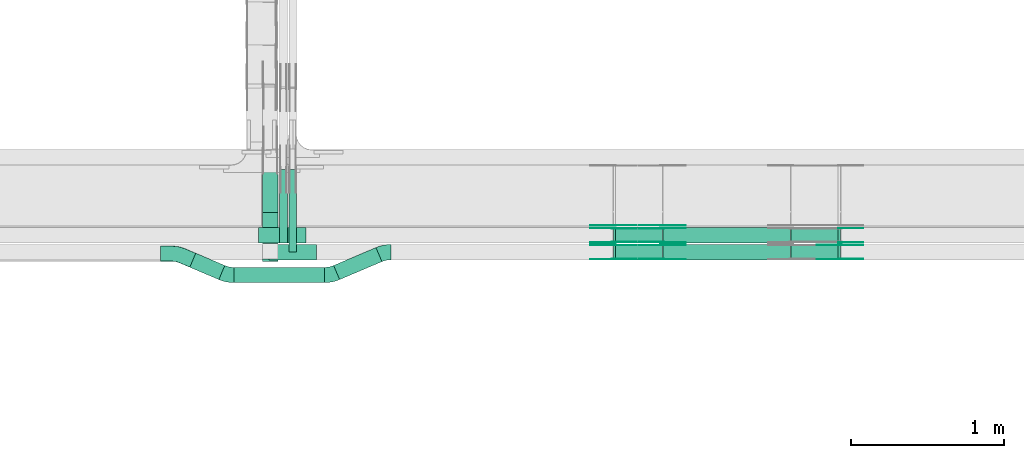
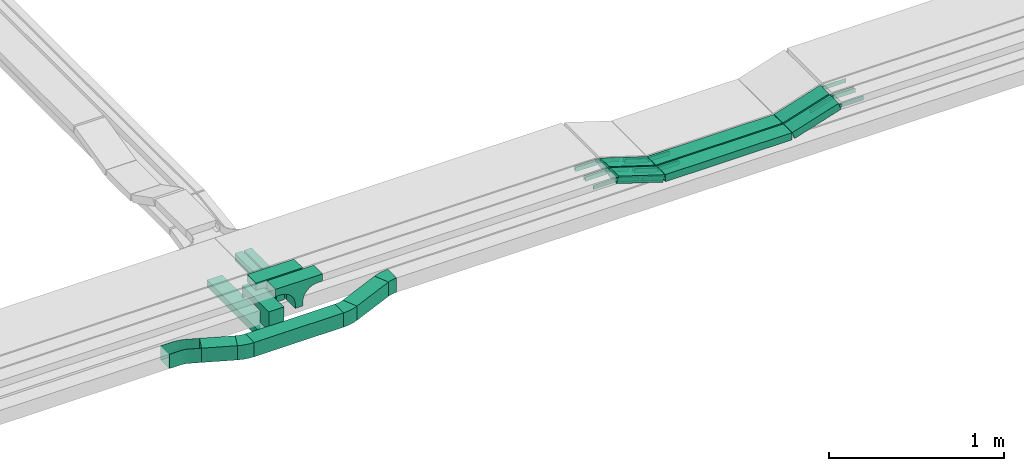
# One storey, part 15 of 27: 33 flow fittings, 12 flow segments.
"""IFC2X3 building model written with IfcOpenShell, lengths in millimetres."""

from ifc_helpers import new_model, entity, si_unit, converted_unit, derived_unit, direction, frame, frame_2d, origin, origin_2d_with_axis, place, context, subcontext, project, spatial, polyline, circle_curve, parameter, trimmed, segment, composite_curve, rectangle, outline, extrude, faceted_brep, source, transform, mapped, material, material_list, type_object, type_shapes, element, save


model = new_model("IFC2X3")

# Units and contexts
model_context = context("Model", 3, precision=0.01, world=origin(), true_north=direction((6.12303176911189e-17, 1.0)))
body_context = subcontext(model_context, "Body", "Model", "MODEL_VIEW")
ifc_project = project(units=[si_unit("LENGTHUNIT", "METRE", prefix="MILLI"), si_unit("AREAUNIT", "SQUARE_METRE"), si_unit("VOLUMEUNIT", "CUBIC_METRE"), converted_unit("PLANEANGLEUNIT", "DEGREE", entity("IfcRatioMeasure", 0.0174532925199433), si_unit("PLANEANGLEUNIT", "RADIAN"), dimensions=[0, 0, 0, 0, 0, 0, 0]), si_unit("MASSUNIT", "GRAM", prefix="KILO"), derived_unit("MASSDENSITYUNIT", [(si_unit("MASSUNIT", "GRAM", prefix="KILO"), 1), (si_unit("LENGTHUNIT", "METRE"), -3)]), derived_unit("MOMENTOFINERTIAUNIT", [(si_unit("LENGTHUNIT", "METRE"), 4)]), si_unit("TIMEUNIT", "SECOND"), si_unit("FREQUENCYUNIT", "HERTZ"), si_unit("THERMODYNAMICTEMPERATUREUNIT", "DEGREE_CELSIUS"), derived_unit("THERMALTRANSMITTANCEUNIT", [(si_unit("MASSUNIT", "GRAM", prefix="KILO"), 1), (si_unit("THERMODYNAMICTEMPERATUREUNIT", "KELVIN"), -1), (si_unit("TIMEUNIT", "SECOND"), -3)]), derived_unit("VOLUMETRICFLOWRATEUNIT", [(si_unit("LENGTHUNIT", "METRE"), 3), (si_unit("TIMEUNIT", "SECOND"), -1)]), derived_unit("MASSFLOWRATEUNIT", [(si_unit("MASSUNIT", "GRAM", prefix="KILO"), 1), (si_unit("TIMEUNIT", "SECOND"), -1)]), derived_unit("ROTATIONALFREQUENCYUNIT", [(si_unit("TIMEUNIT", "SECOND"), -1)]), si_unit("ELECTRICCURRENTUNIT", "AMPERE"), si_unit("ELECTRICVOLTAGEUNIT", "VOLT"), si_unit("POWERUNIT", "WATT"), si_unit("FORCEUNIT", "NEWTON", prefix="KILO"), si_unit("ILLUMINANCEUNIT", "LUX"), si_unit("LUMINOUSFLUXUNIT", "LUMEN"), si_unit("LUMINOUSINTENSITYUNIT", "CANDELA"), derived_unit("USERDEFINED", [(si_unit("MASSUNIT", "GRAM", prefix="KILO"), -1), (si_unit("LENGTHUNIT", "METRE"), -2), (si_unit("TIMEUNIT", "SECOND"), 3), (si_unit("LUMINOUSFLUXUNIT", "LUMEN"), 1)]), derived_unit("LINEARVELOCITYUNIT", [(si_unit("LENGTHUNIT", "METRE"), 1), (si_unit("TIMEUNIT", "SECOND"), -1)]), si_unit("PRESSUREUNIT", "PASCAL"), derived_unit("USERDEFINED", [(si_unit("LENGTHUNIT", "METRE"), -2), (si_unit("MASSUNIT", "GRAM", prefix="KILO"), 1), (si_unit("TIMEUNIT", "SECOND"), -2)]), derived_unit("LINEARFORCEUNIT", [(si_unit("MASSUNIT", "GRAM", prefix="KILO"), 1), (si_unit("LENGTHUNIT", "METRE"), 1), (si_unit("TIMEUNIT", "SECOND"), -2), (si_unit("LENGTHUNIT", "METRE"), -1)]), derived_unit("PLANARFORCEUNIT", [(si_unit("MASSUNIT", "GRAM", prefix="KILO"), 1), (si_unit("LENGTHUNIT", "METRE"), 1), (si_unit("TIMEUNIT", "SECOND"), -2), (si_unit("LENGTHUNIT", "METRE"), -2)])], contexts=[model_context])

# Site, building, storey
site_placement = place(None, origin())
site = spatial("IfcSite", under=ifc_project, at=site_placement, CompositionType="ELEMENT")
building_placement = place(site_placement, origin())
building = spatial("IfcBuilding", under=site, at=building_placement, CompositionType="ELEMENT")
storey_placement = place(building_placement, origin())
storey = spatial("IfcBuildingStorey", under=building, at=storey_placement, CompositionType="ELEMENT", Elevation=0.0)

# Flow segments
cable_carrier_segment_type = type_object("IfcCableCarrierSegmentType", PredefinedType="CABLETRAYSEGMENT")
flow_segment_1_placement = place(storey_placement, frame((46847.77, 8287.3, 2500.0)))
element("IfcFlowSegment", 1, at=flow_segment_1_placement, inside=storey, type_object=cable_carrier_segment_type, context=body_context, shape_type="SweptSolid", body=[
    extrude(rectangle(XDim=724.448158058801, YDim=99.9999999999946, at=origin_2d_with_axis()), frame((50.0, 362.22, 0.0), z_axis=(0.0, 0.0, 1.0), x_axis=(0.0, -1.0, 0.0)), (0.0, 0.0, 1.0), 49.9999999999995),
])
flow_segment_2_placement = place(storey_placement, frame((47020.12, 8350.0, 2720.0)))
element("IfcFlowSegment", 2, at=flow_segment_2_placement, inside=storey, type_object=cable_carrier_segment_type, context=body_context, shape_type="SweptSolid", body=[
    extrude(rectangle(XDim=539.114581342651, YDim=50.000000000006, at=origin_2d_with_axis()), frame((25.0, 269.56, 0.0), z_axis=(0.0, 0.0, 1.0), x_axis=(0.0, -1.0, 0.0)), (0.0, 0.0, 1.0), 49.9999999999995),
])
flow_segment_3_placement = place(storey_placement, frame((46959.82, 8409.33, 2720.0)))
element("IfcFlowSegment", 3, at=flow_segment_3_placement, inside=storey, type_object=cable_carrier_segment_type, context=body_context, shape_type="SweptSolid", body=[
    extrude(rectangle(XDim=479.787085358372, YDim=50.000000000006, at=origin_2d_with_axis()), frame((25.0, 239.89, 0.0), z_axis=(0.0, 0.0, 1.0), x_axis=(0.0, -1.0, 0.0)), (0.0, 0.0, 1.0), 50.0000000000005),
])
flow_segment_4_placement = place(storey_placement, frame((47312.78, 8170.53, 2600.0)))
element("IfcFlowSegment", 4, at=flow_segment_4_placement, inside=storey, type_object=cable_carrier_segment_type, context=body_context, shape_type="SweptSolid", body=[
    extrude(rectangle(XDim=300.279432818873, YDim=99.9999999999931, at=origin_2d_with_axis()), frame((157.74, 104.69, 0.0), z_axis=(0.0, 0.0, 1.0), x_axis=(-0.920504853452416, -0.390731128489331, 0.0)), (0.0, 0.0, 1.0), 99.9999999999994),
])
flow_segment_5_placement = place(storey_placement, frame((46661.88, 8150.26, 2600.0)))
element("IfcFlowSegment", 5, at=flow_segment_5_placement, inside=storey, type_object=cable_carrier_segment_type, context=body_context, shape_type="SweptSolid", body=[
    extrude(rectangle(XDim=590.366719239628, YDim=99.9999999999989, at=origin_2d_with_axis()), frame((295.18, 50.0, 0.0), z_axis=(0.0, 0.0, 1.0), x_axis=(-1.0, 0.0, 0.0)), (0.0, 0.0, 1.0), 100.0),
])
flow_segment_6_placement = place(storey_placement, frame((46372.33, 8170.53, 2600.0)))
element("IfcFlowSegment", 6, at=flow_segment_6_placement, inside=storey, type_object=cable_carrier_segment_type, context=body_context, shape_type="SweptSolid", body=[
    extrude(rectangle(XDim=206.349792090315, YDim=99.9999999999932, at=origin_2d_with_axis()), frame((114.51, 86.34, 0.0), z_axis=(0.0, 0.0, 1.0), x_axis=(0.92050485345242, -0.390731128489323, 0.0)), (0.0, 0.0, 1.0), 100.0),
])
flow_segment_7_placement = place(storey_placement, frame((49465.91, 8410.0, 2750.0)))
element("IfcFlowSegment", 7, at=flow_segment_7_placement, inside=storey, type_object=cable_carrier_segment_type, context=body_context, shape_type="SweptSolid", body=[
    extrude(rectangle(XDim=834.526531103573, YDim=99.9999999999989, at=origin_2d_with_axis()), frame((417.26, 50.0, 0.0), z_axis=(0.0, 0.0, 1.0), x_axis=(-1.0, 0.0, 0.0)), (0.0, 0.0, 1.0), 50.0000000000005),
])
flow_segment_8_placement = place(storey_placement, frame((49465.91, 8300.0, 2750.0)))
element("IfcFlowSegment", 8, at=flow_segment_8_placement, inside=storey, type_object=cable_carrier_segment_type, context=body_context, shape_type="SweptSolid", body=[
    extrude(rectangle(XDim=834.526531103625, YDim=100.000000000001, at=origin_2d_with_axis()), frame((417.26, 50.0, 0.0), z_axis=(0.0, 0.0, 1.0), x_axis=(-1.0, 0.0, 0.0)), (0.0, 0.0, 1.0), 49.9999999999995),
])
flow_segment_9_placement = place(storey_placement, frame((50303.6, 8300.0, 2752.81)))
element("IfcFlowSegment", 9, at=flow_segment_9_placement, inside=storey, type_object=cable_carrier_segment_type, context=body_context, shape_type="SweptSolid", body=[
    extrude(rectangle(XDim=49.9999999999976, YDim=99.9999999999989, at=origin_2d_with_axis()), frame((7.53, 50.0, 23.84), z_axis=(0.953515338379005, 0.0, 0.30134448638721), x_axis=(-0.30134448638721, 0.0, 0.953515338379005)), (0.0, 0.0, 1.0), 320.899186882681),
])
flow_segment_10_placement = place(storey_placement, frame((49141.7, 8300.0, 2752.81)))
element("IfcFlowSegment", 10, at=flow_segment_10_placement, inside=storey, type_object=cable_carrier_segment_type, context=body_context, shape_type="SweptSolid", body=[
    extrude(rectangle(XDim=49.9999999999997, YDim=100.000000000001, at=frame_2d((0.0, 0.0), x_axis=(0.0, 1.0))), frame((7.53, 50.0, 120.54), z_axis=(0.953515338379009, 0.0, -0.301344486387197), x_axis=(0.0, 1.0, 0.0)), (0.0, 0.0, 1.0), 320.899186882732),
])
flow_segment_11_placement = place(storey_placement, frame((50303.6, 8410.0, 2752.81)))
element("IfcFlowSegment", 11, at=flow_segment_11_placement, inside=storey, type_object=cable_carrier_segment_type, context=body_context, shape_type="SweptSolid", body=[
    extrude(rectangle(XDim=49.9999999999976, YDim=99.9999999999989, at=origin_2d_with_axis()), frame((7.53, 50.0, 23.84), z_axis=(0.953515338379005, 0.0, 0.30134448638721), x_axis=(-0.30134448638721, 0.0, 0.953515338379005)), (0.0, 0.0, 1.0), 320.899185830298),
])
flow_segment_12_placement = place(storey_placement, frame((49141.7, 8410.0, 2752.81)))
element("IfcFlowSegment", 12, at=flow_segment_12_placement, inside=storey, type_object=cable_carrier_segment_type, context=body_context, shape_type="SweptSolid", body=[
    extrude(rectangle(XDim=50.0000000000059, YDim=100.000000000001, at=frame_2d((0.0, 0.0), x_axis=(0.0, 1.0))), frame((7.53, 50.0, 120.54), z_axis=(0.953515338379021, 0.0, -0.30134448638716), x_axis=(0.0, 1.0, 0.0)), (0.0, 0.0, 1.0), 320.899186882971),
])

# Flow fittings
ifc_material_1 = material()
cable_carrier_fitting_type_1 = type_object("IfcCableCarrierFittingType", Name="470_DKC_S5_CPO 45 horizontal angle:-", PredefinedType="NOTDEFINED", material=ifc_material_1)
shared_shape_1 = source(origin(), body_context, "Body", "Brep", [
    faceted_brep([(-109.59, -49.2, -49.2), (-109.59, 49.2, -49.2), (-109.59, 49.2, 50.0), (-109.59, 50.0, 50.0), (-109.59, 50.0, -50.0), (-109.59, -50.0, -50.0), (-109.59, -50.0, 50.0), (-109.59, -49.2, 50.0), (-30.52, -50.0, -50.0), (-30.52, -50.0, 50.0), (9.36, -45.98, 50.0), (47.63, -34.1, 50.0), (120.41, -3.21, 50.0), (120.1, -2.47, 50.0), (47.32, -33.36, 50.0), (9.2, -45.2, 50.0), (-30.52, -49.2, 50.0), (-30.52, 49.2, 50.0), (-10.42, 51.22, 50.0), (8.87, 57.21, 50.0), (81.65, 88.11, 50.0), (81.34, 88.84, 50.0), (8.56, 57.95, 50.0), (-10.58, 52.01, 50.0), (-30.52, 50.0, 50.0), (-30.52, -49.2, -49.2), (9.2, -45.2, -49.2), (47.32, -33.36, -49.2), (120.1, -2.47, -49.2), (81.65, 88.11, -49.2), (8.87, 57.21, -49.2), (-10.42, 51.22, -49.2), (-30.52, 49.2, -49.2), (-30.52, 50.0, -50.0), (-10.58, 52.01, -50.0), (8.56, 57.95, -50.0), (81.34, 88.84, -50.0), (120.41, -3.21, -50.0), (47.63, -34.1, -50.0), (9.36, -45.98, -50.0)], [[[0, 1, 2, 3, 4, 5, 6, 7]], [[6, 5, 8, 9]], [[6, 9, 10, 11, 12, 13, 14, 15, 16, 7]], [[2, 17, 18, 19, 20, 21, 22, 23, 24, 3]], [[0, 7, 16, 25]], [[0, 25, 26, 27, 28, 29, 30, 31, 32, 1]], [[2, 1, 32, 17]], [[4, 3, 24, 33]], [[4, 33, 34, 35, 36, 37, 38, 39, 8, 5]], [[9, 8, 39, 10]], [[39, 38, 11, 10]], [[26, 25, 16, 15]], [[15, 14, 27, 26]], [[17, 32, 31, 18]], [[18, 31, 30, 19]], [[34, 33, 24, 23]], [[22, 35, 34, 23]], [[36, 21, 20, 29, 28, 13, 12, 37]], [[11, 38, 37, 12]], [[27, 14, 13, 28]], [[19, 30, 29, 20]], [[35, 22, 21, 36]]]),
])
type_shapes(cable_carrier_fitting_type_1, [shared_shape_1])
flow_fitting_1_placement = place(storey_placement, frame((46290.99, 8340.0, 2650.0), z_axis=(0.0, 0.0, 1.0), x_axis=(-0.92050485345242, 0.390731128489323, 0.0)))
element("IfcFlowFitting", 13, at=flow_fitting_1_placement, inside=storey, type_object=cable_carrier_fitting_type_1, material=ifc_material_1, Name="470_DKC_S5_45 horizontal angle", ObjectType="470_DKC_S5_CPO 45 horizontal angle:-", context=body_context, shape_type="MappedRepresentation", body=[
    mapped(shared_shape_1, transform((0.0, 0.0, 0.0), scale=1.0)),
])
ifc_material_2 = material(Name="G")
cable_carrier_fitting_type_2 = type_object("IfcCableCarrierFittingType", PredefinedType="NOTDEFINED", material=ifc_material_2)
shared_shape_2 = source(origin(), body_context, "Body", "SweptSolid", [
    extrude(outline(composite_curve([segment(trimmed(circle_curve(frame_2d((-44.59, 0.0), x_axis=(1.0, 0.0)), 12.5), [parameter(90.0000000000007)], [parameter(270.0)], True, "PARAMETER"), True, "CONTINUOUS"), segment(polyline([(-44.59, -12.5), (-33.09, -12.5)]), True, "CONTINUOUS"), segment(polyline([(-33.09, -12.5), (-31.23, -14.5)]), True, "CONTINUOUS"), segment(polyline([(-31.23, -14.5), (108.91, -14.5)]), True, "CONTINUOUS"), segment(polyline([(108.91, -14.5), (108.91, 14.5)]), True, "CONTINUOUS"), segment(polyline([(108.91, 14.5), (-31.23, 14.5)]), True, "CONTINUOUS"), segment(polyline([(-31.23, 14.5), (-33.09, 12.5)]), True, "CONTINUOUS"), segment(polyline([(-33.09, 12.5), (-44.59, 12.5)]), True, "CONTINUOUS")], self_intersect=False)), frame((44.59, 0.0, 0.0), z_axis=(0.0, 0.0, -1.0), x_axis=(1.0, 0.0, 0.0)), (0.0, 0.0, -1.0), 2.0),
])
type_shapes(cable_carrier_fitting_type_2, [shared_shape_2])
flow_fitting_2_placement = place(storey_placement, frame((50622.33, 8304.54, 2875.0), z_axis=(0.0, -1.0, 0.0), x_axis=(-0.953515338379004, 0.0, -0.301344486387212)))
element("IfcFlowFitting", 14, at=flow_fitting_2_placement, inside=storey, type_object=cable_carrier_fitting_type_2, material=ifc_material_2, context=body_context, shape_type="MappedRepresentation", body=[
    mapped(shared_shape_2, transform((0.0, 0.0, 0.0), scale=1.0)),
])
cable_carrier_fitting_type_3 = type_object("IfcCableCarrierFittingType", PredefinedType="NOTDEFINED", material=ifc_material_2)
type_shapes(cable_carrier_fitting_type_3, [shared_shape_2])
flow_fitting_3_placement = place(storey_placement, frame((50622.33, 8393.46, 2875.0), z_axis=(0.0, 1.0, 0.0), x_axis=(1.0, 0.0, 0.0)))
element("IfcFlowFitting", 15, at=flow_fitting_3_placement, inside=storey, type_object=cable_carrier_fitting_type_3, material=ifc_material_2, context=body_context, shape_type="MappedRepresentation", body=[
    mapped(shared_shape_2, transform((0.0, 0.0, 0.0), scale=1.0)),
])
for number, where, z_axis, x_axis in (
    (16, (50622.33, 8505.46, 2875.0), (0.0, 1.0, 0.0), (1.0, 0.0, -7.08943298510789e-08)),
    (17, (49460.44, 8304.54, 2775.0), (0.0, -1.0, 0.0), (1.0, 0.0, 0.0)),
):
    element("IfcFlowFitting", number, at=place(storey_placement, frame(where, z_axis=z_axis, x_axis=x_axis)), inside=storey, type_object=cable_carrier_fitting_type_2, material=ifc_material_2, context=body_context, shape_type="MappedRepresentation", body=[
        mapped(shared_shape_2, transform((0.0, 0.0, 0.0), scale=1.0)),
    ])
flow_fitting_4_placement = place(storey_placement, frame((49460.44, 8393.46, 2775.0), z_axis=(0.0, 1.0, 0.0), x_axis=(-0.95351533837899, 0.0, 0.301344486387258)))
element("IfcFlowFitting", 18, at=flow_fitting_4_placement, inside=storey, type_object=cable_carrier_fitting_type_3, material=ifc_material_2, context=body_context, shape_type="MappedRepresentation", body=[
    mapped(shared_shape_2, transform((0.0, 0.0, 0.0), scale=1.0)),
])
flow_fitting_5_placement = place(storey_placement, frame((49144.02, 8304.54, 2875.0), z_axis=(0.0, -1.0, 0.0), x_axis=(-1.0, 0.0, 0.0)))
element("IfcFlowFitting", 19, at=flow_fitting_5_placement, inside=storey, type_object=cable_carrier_fitting_type_2, material=ifc_material_2, context=body_context, shape_type="MappedRepresentation", body=[
    mapped(shared_shape_2, transform((0.0, 0.0, 0.0), scale=1.0)),
])
flow_fitting_6_placement = place(storey_placement, frame((49144.02, 8393.46, 2875.0), z_axis=(0.0, 1.0, 0.0), x_axis=(0.953515338378998, 0.0, -0.301344486387232)))
element("IfcFlowFitting", 20, at=flow_fitting_6_placement, inside=storey, type_object=cable_carrier_fitting_type_3, material=ifc_material_2, context=body_context, shape_type="MappedRepresentation", body=[
    mapped(shared_shape_2, transform((0.0, 0.0, 0.0), scale=1.0)),
])
flow_fitting_7_placement = place(storey_placement, frame((49460.44, 8414.54, 2775.0), z_axis=(0.0, -1.0, 0.0), x_axis=(1.0, 0.0, 0.0)))
element("IfcFlowFitting", 21, at=flow_fitting_7_placement, inside=storey, type_object=cable_carrier_fitting_type_2, material=ifc_material_2, context=body_context, shape_type="MappedRepresentation", body=[
    mapped(shared_shape_2, transform((0.0, 0.0, 0.0), scale=1.0)),
])
flow_fitting_8_placement = place(storey_placement, frame((49460.44, 8503.46, 2775.0), z_axis=(0.0, 1.0, 0.0), x_axis=(-0.953515338379028, 0.0, 0.301344486387136)))
element("IfcFlowFitting", 22, at=flow_fitting_8_placement, inside=storey, type_object=cable_carrier_fitting_type_3, material=ifc_material_2, context=body_context, shape_type="MappedRepresentation", body=[
    mapped(shared_shape_2, transform((0.0, 0.0, 0.0), scale=1.0)),
])
flow_fitting_9_placement = place(storey_placement, frame((49144.02, 8414.54, 2875.0), z_axis=(0.0, -1.0, 0.0), x_axis=(-1.0, 0.0, 0.0)))
element("IfcFlowFitting", 23, at=flow_fitting_9_placement, inside=storey, type_object=cable_carrier_fitting_type_2, material=ifc_material_2, context=body_context, shape_type="MappedRepresentation", body=[
    mapped(shared_shape_2, transform((0.0, 0.0, 0.0), scale=1.0)),
])
flow_fitting_10_placement = place(storey_placement, frame((49144.02, 8503.46, 2875.0), z_axis=(0.0, 1.0, 0.0), x_axis=(0.953515338379063, 0.0, -0.301344486387026)))
element("IfcFlowFitting", 24, at=flow_fitting_10_placement, inside=storey, type_object=cable_carrier_fitting_type_3, material=ifc_material_2, context=body_context, shape_type="MappedRepresentation", body=[
    mapped(shared_shape_2, transform((0.0, 0.0, 0.0), scale=1.0)),
])
for number, where, z_axis, x_axis in (
    (25, (49460.44, 8524.54, 2775.0), (0.0, -1.0, 0.0), (1.0, 0.0, 0.0)),
    (26, (49144.02, 8524.54, 2875.0), (0.0, -1.0, 0.0), (-1.0, 0.0, 0.0)),
):
    element("IfcFlowFitting", number, at=place(storey_placement, frame(where, z_axis=z_axis, x_axis=x_axis)), inside=storey, type_object=cable_carrier_fitting_type_2, material=ifc_material_2, context=body_context, shape_type="MappedRepresentation", body=[
        mapped(shared_shape_2, transform((0.0, 0.0, 0.0), scale=1.0)),
    ])
cable_carrier_fitting_type_4 = type_object("IfcCableCarrierFittingType", PredefinedType="NOTDEFINED", material=ifc_material_2)
shared_shape_3 = source(origin(), body_context, "Body", "SweptSolid", [
    extrude(outline(composite_curve([segment(trimmed(circle_curve(frame_2d((-44.59, 0.0), x_axis=(1.0, 0.0)), 12.5), [parameter(90.0000000000007)], [parameter(270.0)], True, "PARAMETER"), True, "CONTINUOUS"), segment(polyline([(-44.59, -12.5), (-33.09, -12.5)]), True, "CONTINUOUS"), segment(polyline([(-33.09, -12.5), (-31.23, -14.5)]), True, "CONTINUOUS"), segment(polyline([(-31.23, -14.5), (108.91, -14.5)]), True, "CONTINUOUS"), segment(polyline([(108.91, -14.5), (108.91, 14.5)]), True, "CONTINUOUS"), segment(polyline([(108.91, 14.5), (-31.23, 14.5)]), True, "CONTINUOUS"), segment(polyline([(-31.23, 14.5), (-33.09, 12.5)]), True, "CONTINUOUS"), segment(polyline([(-33.09, 12.5), (-44.59, 12.5)]), True, "CONTINUOUS")], self_intersect=False)), frame((44.59, 0.0, 0.0)), (0.0, 0.0, 1.0), 2.0),
])
type_shapes(cable_carrier_fitting_type_4, [shared_shape_3])
flow_fitting_11_placement = place(storey_placement, frame((50622.33, 8395.46, 2875.0), z_axis=(0.0, 1.0, 0.0), x_axis=(-0.953515338379004, 0.0, -0.301344486387212)))
element("IfcFlowFitting", 27, at=flow_fitting_11_placement, inside=storey, type_object=cable_carrier_fitting_type_4, material=ifc_material_2, context=body_context, shape_type="MappedRepresentation", body=[
    mapped(shared_shape_3, transform((0.0, 0.0, 0.0), scale=1.0)),
])
cable_carrier_fitting_type_5 = type_object("IfcCableCarrierFittingType", PredefinedType="NOTDEFINED", material=ifc_material_2)
type_shapes(cable_carrier_fitting_type_5, [shared_shape_3])
flow_fitting_12_placement = place(storey_placement, frame((50622.33, 8306.54, 2875.0), z_axis=(0.0, -1.0, 0.0), x_axis=(1.0, 0.0, 0.0)))
element("IfcFlowFitting", 28, at=flow_fitting_12_placement, inside=storey, type_object=cable_carrier_fitting_type_5, material=ifc_material_2, context=body_context, shape_type="MappedRepresentation", body=[
    mapped(shared_shape_3, transform((0.0, 0.0, 0.0), scale=1.0)),
])
for number, where, z_axis, x_axis in (
    (29, (50622.33, 8414.54, 2875.0), (0.0, -1.0, 0.0), (1.0, 0.0, -7.08943298510789e-08)),
    (30, (49460.44, 8395.46, 2775.0), (0.0, 1.0, 0.0), (1.0, 0.0, 0.0)),
):
    element("IfcFlowFitting", number, at=place(storey_placement, frame(where, z_axis=z_axis, x_axis=x_axis)), inside=storey, type_object=cable_carrier_fitting_type_4, material=ifc_material_2, context=body_context, shape_type="MappedRepresentation", body=[
        mapped(shared_shape_3, transform((0.0, 0.0, 0.0), scale=1.0)),
    ])
flow_fitting_13_placement = place(storey_placement, frame((49460.44, 8306.54, 2775.0), z_axis=(0.0, -1.0, 0.0), x_axis=(-0.95351533837899, 0.0, 0.301344486387258)))
element("IfcFlowFitting", 31, at=flow_fitting_13_placement, inside=storey, type_object=cable_carrier_fitting_type_5, material=ifc_material_2, context=body_context, shape_type="MappedRepresentation", body=[
    mapped(shared_shape_3, transform((0.0, 0.0, 0.0), scale=1.0)),
])
flow_fitting_14_placement = place(storey_placement, frame((49144.02, 8395.46, 2875.0), z_axis=(0.0, 1.0, 0.0), x_axis=(-1.0, 0.0, 0.0)))
element("IfcFlowFitting", 32, at=flow_fitting_14_placement, inside=storey, type_object=cable_carrier_fitting_type_4, material=ifc_material_2, context=body_context, shape_type="MappedRepresentation", body=[
    mapped(shared_shape_3, transform((0.0, 0.0, 0.0), scale=1.0)),
])
flow_fitting_15_placement = place(storey_placement, frame((49144.02, 8306.54, 2875.0), z_axis=(0.0, -1.0, 0.0), x_axis=(0.953515338378998, 0.0, -0.301344486387232)))
element("IfcFlowFitting", 33, at=flow_fitting_15_placement, inside=storey, type_object=cable_carrier_fitting_type_5, material=ifc_material_2, context=body_context, shape_type="MappedRepresentation", body=[
    mapped(shared_shape_3, transform((0.0, 0.0, 0.0), scale=1.0)),
])
flow_fitting_16_placement = place(storey_placement, frame((49460.44, 8505.46, 2775.0), z_axis=(0.0, 1.0, 0.0), x_axis=(1.0, 0.0, 0.0)))
element("IfcFlowFitting", 34, at=flow_fitting_16_placement, inside=storey, type_object=cable_carrier_fitting_type_4, material=ifc_material_2, context=body_context, shape_type="MappedRepresentation", body=[
    mapped(shared_shape_3, transform((0.0, 0.0, 0.0), scale=1.0)),
])
flow_fitting_17_placement = place(storey_placement, frame((49460.44, 8416.54, 2775.0), z_axis=(0.0, -1.0, 0.0), x_axis=(-0.953515338379028, 0.0, 0.301344486387136)))
element("IfcFlowFitting", 35, at=flow_fitting_17_placement, inside=storey, type_object=cable_carrier_fitting_type_5, material=ifc_material_2, context=body_context, shape_type="MappedRepresentation", body=[
    mapped(shared_shape_3, transform((0.0, 0.0, 0.0), scale=1.0)),
])
flow_fitting_18_placement = place(storey_placement, frame((49144.02, 8505.46, 2875.0), z_axis=(0.0, 1.0, 0.0), x_axis=(-1.0, 0.0, 0.0)))
element("IfcFlowFitting", 36, at=flow_fitting_18_placement, inside=storey, type_object=cable_carrier_fitting_type_4, material=ifc_material_2, context=body_context, shape_type="MappedRepresentation", body=[
    mapped(shared_shape_3, transform((0.0, 0.0, 0.0), scale=1.0)),
])
for number, where, z_axis, x_axis in (
    (37, (49144.02, 8416.54, 2875.0), (0.0, -1.0, 0.0), (0.953515338379063, 0.0, -0.301344486387026)),
    (38, (49460.44, 8526.54, 2775.0), (0.0, -1.0, 0.0), (-0.953515338379008, 0.0, 0.3013444863872)),
    (39, (49144.02, 8526.54, 2875.0), (0.0, -1.0, 0.0), (0.953515338379043, 0.0, -0.301344486387091)),
):
    element("IfcFlowFitting", number, at=place(storey_placement, frame(where, z_axis=z_axis, x_axis=x_axis)), inside=storey, type_object=cable_carrier_fitting_type_5, material=ifc_material_2, context=body_context, shape_type="MappedRepresentation", body=[
        mapped(shared_shape_3, transform((0.0, 0.0, 0.0), scale=1.0)),
    ])
ifc_material_list = material_list([ifc_material_1, ifc_material_1, ifc_material_1, ifc_material_1, ifc_material_1])
cable_carrier_fitting_type_6 = type_object("IfcCableCarrierFittingType", PredefinedType="NOTDEFINED", material=ifc_material_list)
shared_shape_4 = source(origin(), body_context, "Body", "SweptSolid", [
    extrude(outline(composite_curve([segment(polyline([(-61.86, -174.29), (-7.86, -174.29)]), True, "CONTINUOUS"), segment(polyline([(-7.86, -174.29), (-7.86, 25.71)]), True, "CONTINUOUS"), segment(trimmed(circle_curve(frame_2d((-2.86, 25.71), x_axis=(0.0, -1.0)), 5.0), [parameter(180.0)], [parameter(270.0)], True, "PARAMETER"), False, "CONTINUOUS"), segment(polyline([(-2.86, 30.71), (71.14, 30.71)]), True, "CONTINUOUS"), segment(polyline([(71.14, 30.71), (71.14, 130.71)]), True, "CONTINUOUS"), segment(polyline([(71.14, 130.71), (-61.86, 130.71)]), True, "CONTINUOUS"), segment(polyline([(-61.86, 130.71), (-61.86, -174.29)]), True, "CONTINUOUS")], self_intersect=False)), frame((-74.29, -50.0, 42.14), z_axis=(0.0, 1.0, 0.0), x_axis=(0.0, 0.0, -1.0)), (0.0, 0.0, 1.0), 0.800000000000055),
    extrude(rectangle(XDim=0.799999999999954, YDim=100.0, at=origin_2d_with_axis()), frame((99.6, 0.0, 17.5), z_axis=(0.0, 0.0, 1.0), x_axis=(-1.0, 0.0, 0.0)), (0.0, 0.0, 1.0), 86.4999999999732),
    extrude(rectangle(XDim=305.0, YDim=100.0, at=origin_2d_with_axis()), frame((-52.5, 0.0, 103.2), z_axis=(0.0, 0.0, 1.0), x_axis=(-1.0, 0.0, 0.0)), (0.0, 0.0, 1.0), 0.800000000000106),
    extrude(rectangle(XDim=0.799999999999852, YDim=98.4000000000001, at=origin_2d_with_axis()), frame((-204.6, 0.0, -29.0), z_axis=(0.0, 0.0, 1.0), x_axis=(-1.0, 0.0, 0.0)), (0.0, 0.0, 1.0), 133.0),
    extrude(outline(composite_curve([segment(polyline([(-61.86, -174.29), (-7.86, -174.29)]), True, "CONTINUOUS"), segment(polyline([(-7.86, -174.29), (-7.86, 25.71)]), True, "CONTINUOUS"), segment(trimmed(circle_curve(frame_2d((-2.86, 25.71), x_axis=(0.0, -1.0)), 5.0), [parameter(180.0)], [parameter(270.0)], True, "PARAMETER"), False, "CONTINUOUS"), segment(polyline([(-2.86, 30.71), (71.14, 30.71)]), True, "CONTINUOUS"), segment(polyline([(71.14, 30.71), (71.14, 130.71)]), True, "CONTINUOUS"), segment(polyline([(71.14, 130.71), (-61.86, 130.71)]), True, "CONTINUOUS"), segment(polyline([(-61.86, 130.71), (-61.86, -174.29)]), True, "CONTINUOUS")], self_intersect=False)), frame((-74.29, 49.2, 42.14), z_axis=(0.0, 1.0, 0.0), x_axis=(0.0, 0.0, -1.0)), (0.0, 0.0, 1.0), 0.799999999999835),
])
type_shapes(cable_carrier_fitting_type_6, [shared_shape_4])
flow_fitting_19_placement = place(storey_placement, frame((46897.77, 8510.17, 2650.0), z_axis=(0.0, 0.0, 1.0), x_axis=(0.0, 1.0, 0.0)))
element("IfcFlowFitting", 40, at=flow_fitting_19_placement, inside=storey, type_object=cable_carrier_fitting_type_6, material=ifc_material_1, Name="470_DKC_S5_vertical T-shaped cover", context=body_context, shape_type="MappedRepresentation", body=[
    mapped(shared_shape_4, transform((0.0, 0.0, 0.0), scale=1.0)),
])
cable_carrier_fitting_type_7 = type_object("IfcCableCarrierFittingType", PredefinedType="NOTDEFINED", material=ifc_material_1)
shared_shape_5 = source(origin(), body_context, "Body", "SweptSolid", [
    extrude(outline(composite_curve([segment(polyline([(-155.0, -85.8), (155.0, -85.8)]), True, "CONTINUOUS"), segment(polyline([(155.0, -85.8), (155.0, -35.8)]), True, "CONTINUOUS"), segment(polyline([(155.0, -35.8), (125.0, -35.8)]), True, "CONTINUOUS"), segment(trimmed(circle_curve(frame_2d((125.0, 64.2), x_axis=(1.0, 0.0)), 99.9999999999926), [parameter(180.0)], [parameter(269.999999999985)], True, "PARAMETER"), False, "CONTINUOUS"), segment(polyline([(25.0, 64.2), (25.0, 93.2)]), True, "CONTINUOUS"), segment(polyline([(25.0, 93.2), (-25.0, 93.2)]), True, "CONTINUOUS"), segment(polyline([(-25.0, 93.2), (-25.0, 64.2)]), True, "CONTINUOUS"), segment(trimmed(circle_curve(frame_2d((-125.0, 64.2), x_axis=(1.0, 0.0)), 99.9999999999768), [parameter(270.0)], [parameter(359.999999999955)], True, "PARAMETER"), False, "CONTINUOUS"), segment(polyline([(-125.0, -35.8), (-155.0, -35.8)]), True, "CONTINUOUS"), segment(polyline([(-155.0, -35.8), (-155.0, -85.8)]), True, "CONTINUOUS")], self_intersect=False)), frame((155.0, -50.0, -60.8), z_axis=(0.0, 1.0, 0.0), x_axis=(1.0, 0.0, 0.0)), (0.0, 0.0, 1.0), 100.0),
])
type_shapes(cable_carrier_fitting_type_7, [shared_shape_5])
for number, where, z_axis, x_axis in (
    (41, (47132.17, 8460.0, 2875.0), (0.0, 0.0, 1.0), (-1.0, 0.0, 0.0)),
    (42, (47199.82, 8350.0, 2875.0), (0.0, 0.0, 1.0), (-1.0, 0.0, 0.0)),
):
    element("IfcFlowFitting", number, at=place(storey_placement, frame(where, z_axis=z_axis, x_axis=x_axis)), inside=storey, type_object=cable_carrier_fitting_type_7, material=ifc_material_1, context=body_context, shape_type="MappedRepresentation", body=[
        mapped(shared_shape_5, transform((0.0, 0.0, 0.0), scale=1.0)),
    ])
cable_carrier_fitting_type_8 = type_object("IfcCableCarrierFittingType", Name="470_DKC_S5_Variable Angle Elbow 0-45:-", PredefinedType="NOTDEFINED", material=ifc_material_1)
shared_shape_6 = source(origin(), body_context, "Body", "SweptSolid", [
    extrude(outline(composite_curve([segment(polyline([(-40.05, -58.05), (-39.05, -58.05)]), True, "CONTINUOUS"), segment(trimmed(circle_curve(frame_2d((-39.05, 191.95), x_axis=(0.0, -1.0)), 250.0), [parameter(0.0)], [parameter(23.0000000000002)], True, "PARAMETER"), True, "CONTINUOUS"), segment(polyline([(58.63, -38.17), (59.55, -37.78)]), True, "CONTINUOUS"), segment(polyline([(59.55, -37.78), (20.48, 54.27)]), True, "CONTINUOUS"), segment(polyline([(20.48, 54.27), (19.56, 53.88)]), True, "CONTINUOUS"), segment(trimmed(circle_curve(frame_2d((-39.05, 191.95), x_axis=(0.0, -1.0)), 150.0), [parameter(0.0)], [parameter(23.0000000000002)], True, "PARAMETER"), False, "CONTINUOUS"), segment(polyline([(-39.05, 41.95), (-40.05, 41.95)]), True, "CONTINUOUS"), segment(polyline([(-40.05, 41.95), (-40.05, -58.05)]), True, "CONTINUOUS")], self_intersect=False)), frame((-1.64, 8.05, -50.0)), (0.0, 0.0, 1.0), 100.0),
])
type_shapes(cable_carrier_fitting_type_8, [shared_shape_6])
flow_fitting_20_placement = place(storey_placement, frame((47293.94, 8200.26, 2650.0)))
element("IfcFlowFitting", 43, at=flow_fitting_20_placement, inside=storey, type_object=cable_carrier_fitting_type_8, material=ifc_material_1, Name="470_DKC_S5_Variable Angle Elbow 0-45:-", ObjectType="470_DKC_S5_Variable Angle Elbow 0-45:-", context=body_context, shape_type="MappedRepresentation", body=[
    mapped(shared_shape_6, transform((0.0, 0.0, 0.0), scale=1.0)),
])
for number, where, z_axis, x_axis, name in (
    (44, (46620.19, 8200.26, 2650.0), (0.0, 0.0, 1.0), (0.920504853452416, -0.390731128489332, 0.0), "470_DKC_S5_Variable Angle Elbow 0-45:-"),
    (45, (47647.1, 8350.17, 2650.0), (0.0, 0.0, 1.0), (-1.0, 0.0, 0.0), "470_DKC_S5_Variable Angle Elbow 0-45:-"),
):
    element("IfcFlowFitting", number, at=place(storey_placement, frame(where, z_axis=z_axis, x_axis=x_axis)), inside=storey, type_object=cable_carrier_fitting_type_8, material=ifc_material_1, Name=name, ObjectType="470_DKC_S5_Variable Angle Elbow 0-45:-", context=body_context, shape_type="MappedRepresentation", body=[
        mapped(shared_shape_6, transform((0.0, 0.0, 0.0), scale=1.0)),
    ])

save(model, "model.ifc")
